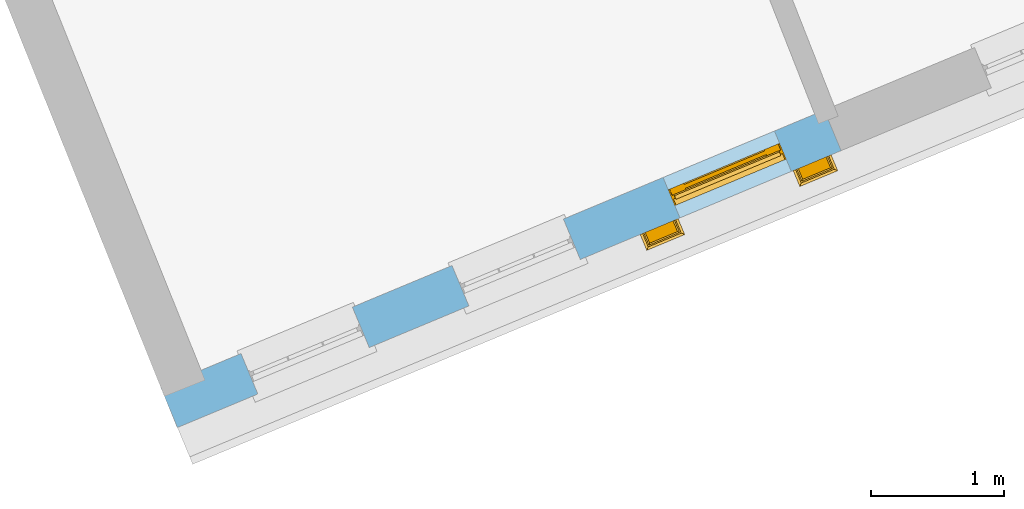
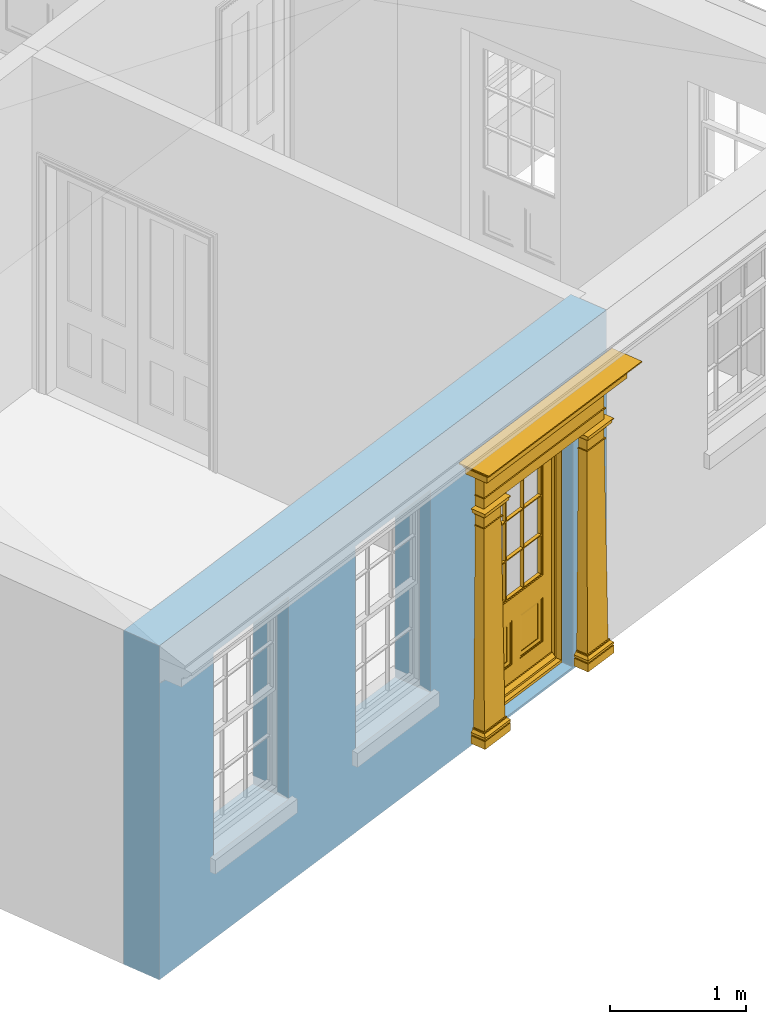
# One storey, part 4 of 19: 1 door, 3 openings, plus 1 element that does not belong to this part.
"""IFC2X3 building model written with IfcOpenShell, lengths in metres."""

import ifcopenshell
import ifcopenshell.guid

model = None  # the IFC model being written
_history = None  # IfcOwnerHistory: only IFC2X3 demands one
_inside = {}  # id of a spatial element -> (the spatial element, [elements in it])
_under = {}  # id of a project, library or spatial element -> (it, [spatial elements below it])
_declared = {}  # id of a project -> (the project, [libraries it declares])
_typed = {}  # id of a type object -> (the type object, [elements of that type])
_made_of = {}  # id of a material, layer set ... -> (it, [elements and type objects made of it])


def new_model(schema):
    """Start an empty IFC model of exactly this schema.

    Asked for "IFC4X3", IfcOpenShell would pick the latest addendum, in which some entities
    have other attributes; the version numbers below select the first issue.
    IFC2X3 requires an IfcOwnerHistory on every rooted entity: one is made here for all.
    """
    global model, _history
    if schema == "IFC4X3":
        model = ifcopenshell.file(schema_version=(4, 3, 0, 0))
    else:
        model = ifcopenshell.file(schema=schema)
    _inside.clear()
    _under.clear()
    _declared.clear()
    _typed.clear()
    _made_of.clear()
    _history = None
    if model.schema == "IFC2X3":
        org = make("IfcOrganization", Name="unknown")
        user = make(
            "IfcPersonAndOrganization",
            ThePerson=make("IfcPerson", FamilyName="unknown"),
            TheOrganization=org,
        )
        app = make(
            "IfcApplication",
            ApplicationDeveloper=org,
            Version="unknown",
            ApplicationFullName="unknown",
            ApplicationIdentifier="unknown",
        )
        _history = make(
            "IfcOwnerHistory",
            OwningUser=user,
            OwningApplication=app,
            ChangeAction="ADDED",
            CreationDate=0,
        )
    return model


def make(cls, **values):
    """One entity of the class cls with the attributes given. An attribute that is None is left unset."""
    return model.create_entity(
        cls, **{name: value for name, value in values.items() if value is not None}
    )


def rooted(cls, **values):
    """An entity with a GlobalId (a new one), such as an element, a storey or a relation."""
    return make(cls, GlobalId=ifcopenshell.guid.new(), OwnerHistory=_history, **values)


def si_unit(unit_type, name, prefix=None):
    """IfcSIUnit, for example si_unit("LENGTHUNIT", "METRE", prefix="MILLI")."""
    return make("IfcSIUnit", UnitType=unit_type, Prefix=prefix, Name=name)


def assignment(units):
    """IfcUnitAssignment: the units of a project."""
    return None if units is None else make("IfcUnitAssignment", Units=units)


def point(xyz):
    """IfcCartesianPoint."""
    return None if xyz is None else make("IfcCartesianPoint", Coordinates=xyz)


def direction(xyz):
    """IfcDirection."""
    return None if xyz is None else make("IfcDirection", DirectionRatios=xyz)


def frame(location, z_axis=None, x_axis=None):
    """IfcAxis2Placement3D, a coordinate frame: its origin and axes. An axis left out is left unset."""
    return make(
        "IfcAxis2Placement3D",
        Location=point(location),
        Axis=direction(z_axis),
        RefDirection=direction(x_axis),
    )


def origin():
    """The frame at (0, 0, 0) with its axes left unset."""
    return frame((0.0, 0.0, 0.0))


def place(relative_to, where):
    """IfcLocalPlacement: puts the frame where relative to a parent placement (None: the world)."""
    return make(
        "IfcLocalPlacement", PlacementRelTo=relative_to, RelativePlacement=where
    )


def context(
    kind, dimensions, precision=None, world=None, true_north=None, identifier=None
):
    """IfcGeometricRepresentationContext, for example the 3D "Model" context."""
    return make(
        "IfcGeometricRepresentationContext",
        ContextIdentifier=identifier,
        ContextType=kind,
        CoordinateSpaceDimension=dimensions,
        Precision=precision,
        WorldCoordinateSystem=world,
        TrueNorth=true_north,
    )


def subcontext(parent, identifier, kind, view, scale=None):
    """IfcGeometricRepresentationSubContext, for example "Body" below "Model"."""
    return make(
        "IfcGeometricRepresentationSubContext",
        ContextIdentifier=identifier,
        ContextType=kind,
        ParentContext=parent,
        TargetScale=scale,
        TargetView=view,
    )


def project(units=None, contexts=None):
    """IfcProject with its units and contexts."""
    return rooted(
        "IfcProject",
        Name="project",
        RepresentationContexts=contexts,
        UnitsInContext=assignment(units),
    )


def spatial(cls, under=None, at=None, **own):
    """A site, building, storey or space (cls), placed at a placement, below another one or the project."""
    s = rooted(cls, ObjectPlacement=at, **own)
    if under is not None:
        _under.setdefault(under.id(), (under, []))[1].append(s)
    return s


def polyline(points):
    """IfcPolyline through the points."""
    return make("IfcPolyline", Points=[point(p) for p in points])


def outline(outer, holes=None, kind="AREA"):
    """IfcArbitraryClosedProfileDef: a profile drawn as a closed curve; with holes, ...WithVoids."""
    if holes is None:
        return make("IfcArbitraryClosedProfileDef", ProfileType=kind, OuterCurve=outer)
    return make(
        "IfcArbitraryProfileDefWithVoids",
        ProfileType=kind,
        OuterCurve=outer,
        InnerCurves=holes,
    )


def extrude(swept, where, along, depth):
    """IfcExtrudedAreaSolid: the profile swept, set in the frame where, extruded along a direction by depth."""
    return make(
        "IfcExtrudedAreaSolid",
        SweptArea=swept,
        Position=where,
        ExtrudedDirection=direction(along),
        Depth=depth,
    )


def faces_of(points, faces, orient=None, outer=None):
    """IfcFace entities. A face is a list of loops; a loop is a list of indices into points, from 0.

    orient and outer hold one flag for each loop. By default every Orientation is true, the
    first loop of a face is its IfcFaceOuterBound and the others are IfcFaceBound.
    """
    made = []
    for i, loops in enumerate(faces):
        bounds = []
        for j, loop in enumerate(loops):
            is_outer = j == 0 if outer is None else outer[i][j]
            bounds.append(
                make(
                    "IfcFaceOuterBound" if is_outer else "IfcFaceBound",
                    Bound=make("IfcPolyLoop", Polygon=[points[k] for k in loop]),
                    Orientation=True if orient is None else orient[i][j],
                )
            )
        made.append(make("IfcFace", Bounds=bounds))
    return made


def faceted_brep(points, faces, orient=None, outer=None, voids=None):
    """IfcFacetedBrep: a solid bounded by flat faces; with voids (closed shells), ...WithVoids."""
    shared = [point(p) for p in points]
    hull = make("IfcClosedShell", CfsFaces=faces_of(shared, faces, orient, outer))
    if voids is None:
        return make("IfcFacetedBrep", Outer=hull)
    return make(
        "IfcFacetedBrepWithVoids",
        Outer=hull,
        Voids=[
            make(cls, CfsFaces=faces_of(shared, fs, o, b)) for cls, fs, o, b in voids
        ],
    )


def shape(context_of_items, identifier, shape_type, items):
    """IfcShapeRepresentation: the items that make up one representation, for example the "Body"."""
    return make(
        "IfcShapeRepresentation",
        ContextOfItems=context_of_items,
        RepresentationIdentifier=identifier,
        RepresentationType=shape_type,
        Items=items,
    )


def material(Name=None, Category=None):
    """IfcMaterial."""
    return make("IfcMaterial", Name=Name, Category=Category)


def layer(
    of_material, thickness, ventilated=None, Name=None, Category=None, Priority=None
):
    """IfcMaterialLayer: one layer of a wall or slab, of a material (None: an air gap)."""
    return make(
        "IfcMaterialLayer",
        Material=of_material,
        LayerThickness=thickness,
        IsVentilated=ventilated,
        Name=Name,
        Category=Category,
        Priority=Priority,
    )


def layer_set(layers, Name=None):
    """IfcMaterialLayerSet."""
    return make("IfcMaterialLayerSet", MaterialLayers=layers, LayerSetName=Name)


def layer_usage(for_layer_set, set_direction, sense, offset, extent=None):
    """IfcMaterialLayerSetUsage: how a layer set lies in its element."""
    return make(
        "IfcMaterialLayerSetUsage",
        ForLayerSet=for_layer_set,
        LayerSetDirection=set_direction,
        DirectionSense=sense,
        OffsetFromReferenceLine=offset,
        ReferenceExtent=extent,
    )


def made_of(thing, what):
    """Note that an element or type object is made of a material, layer set ...; save() writes the relation."""
    if what is not None:
        _made_of.setdefault(what.id(), (what, []))[1].append(thing)
    return thing


def element(
    cls,
    number,
    at=None,
    inside=None,
    cuts=None,
    type_object=None,
    material=None,
    context=None,
    identifier="Body",
    shape_type=None,
    held_by="IfcProductDefinitionShape",
    body=None,
    shapes=None,
    **own,
):
    """One element of the class cls, such as IfcWall. Its Tag is "e" and its number.

    at: its placement. inside: the storey or other place that contains it. cuts: it is an
    opening in that element (IfcRelVoidsElement). A single representation is given by context,
    identifier, shape_type and body (its items); several are given by shapes. held_by: the class
    of the entity that holds the representations. save() writes the other relations.
    """
    e = rooted(cls, Tag="e%d" % number, ObjectPlacement=at, **own)
    if body is not None:
        shapes = [shape(context, identifier, shape_type, body)]
    if shapes is not None:
        e.Representation = make(held_by, Representations=shapes)
    if inside is not None:
        _inside.setdefault(inside.id(), (inside, []))[1].append(e)
    if cuts is not None:
        rooted(
            "IfcRelVoidsElement", RelatingBuildingElement=cuts, RelatedOpeningElement=e
        )
    if type_object is not None:
        _typed.setdefault(type_object.id(), (type_object, []))[1].append(e)
    return made_of(e, material)


def fill(opening, filler):
    """IfcRelFillsElement: the door or window that sits in an opening."""
    return rooted(
        "IfcRelFillsElement",
        RelatingOpeningElement=opening,
        RelatedBuildingElement=filler,
    )


def aggregate(whole, parts):
    """IfcRelAggregates: a whole, such as a stair, and the parts it consists of."""
    return rooted("IfcRelAggregates", RelatingObject=whole, RelatedObjects=parts)


def save(model, path):
    """Write the relations noted so far, then the file.

    IfcRelAggregates (storeys below a building ...), IfcRelContainedInSpatialStructure (elements
    in a storey), IfcRelDefinesByType, IfcRelAssociatesMaterial and IfcRelDeclares: one each for
    every whole, place, type object, material and project.
    """
    for whole, parts in _under.values():
        aggregate(whole, parts)
    for where, things in _inside.values():
        rooted(
            "IfcRelContainedInSpatialStructure",
            RelatedElements=things,
            RelatingStructure=where,
        )
    for kind, things in _typed.values():
        rooted("IfcRelDefinesByType", RelatedObjects=things, RelatingType=kind)
    for what, things in _made_of.values():
        rooted("IfcRelAssociatesMaterial", RelatedObjects=things, RelatingMaterial=what)
    for by, libraries in _declared.values():
        rooted("IfcRelDeclares", RelatingContext=by, RelatedDefinitions=libraries)
    model.write(path)


model = new_model("IFC2X3")

# Units and contexts
model_context = context("Model", 3, world=origin())
body_context = subcontext(model_context, "Body", "Model", "MODEL_VIEW")
ifc_project = project(units=[si_unit("PLANEANGLEUNIT", "RADIAN"), si_unit("MASSUNIT", "GRAM", prefix="KILO"), si_unit("FORCEUNIT", "NEWTON", prefix="KILO"), si_unit("LENGTHUNIT", "METRE")], contexts=[model_context])

# Site, building, storey
site_placement = place(None, origin())
site = spatial("IfcSite", under=ifc_project, at=site_placement, CompositionType="ELEMENT")
building_placement = place(None, origin())
building = spatial("IfcBuilding", under=site, at=building_placement, Name="Building plot-0", CompositionType="ELEMENT")
storey_placement = place(None, origin())
storey = spatial("IfcBuildingStorey", under=building, at=storey_placement, Name="Floor 0", CompositionType="ELEMENT", Elevation=0.0)

# Wall, openings, door
ifc_material = material(Name="Masonry")
ifc_layer = layer(ifc_material, 0.33, ventilated=False)
ifc_layer_set = layer_set([ifc_layer], Name="My Wall")
ifc_layer_usage = layer_usage(ifc_layer_set, "AXIS2", "NEGATIVE", 0.08)
wall_placement = place(storey_placement, origin())
wall = element("IfcWallStandardCase", 1, at=wall_placement, inside=storey, material=ifc_layer_usage, Name="exterior", context=body_context, shape_type="SweptSolid", body=[
    extrude(outline(polyline([(16.1700267177394, 20.5032297368677), (16.2971036159413, 20.1986784900415), (21.3007494176732, 22.2864971898878), (21.1736725194713, 22.591048436714), (16.1700267177394, 20.5032297368677)])), origin(), (0.0, 0.0, 1.0), 3.0),
])
opening_1_placement = place(storey_placement, frame((0.0, 0.0, 0.75)))
element("IfcOpeningElement", 2, at=opening_1_placement, cuts=wall, Name="Opening", ObjectType="Opening", context=body_context, shape_type="SweptSolid", body=[
    extrude(outline(polyline([(16.9034002165821, 20.4516615009559), (17.7432233517695, 20.8020856747854), (17.6161464535675, 21.1066369216116), (16.7763233183802, 20.756212747782), (16.9034002165821, 20.4516615009559)])), origin(), (0.0, 0.0, 1.0), 1.82),
])
opening_2_placement = place(storey_placement, frame((0.0, 0.0, 0.75)))
element("IfcOpeningElement", 3, at=opening_2_placement, cuts=wall, Name="Opening", ObjectType="Opening", context=body_context, shape_type="SweptSolid", body=[
    extrude(outline(polyline([(18.4943752699811, 21.1155109417627), (19.3341984051684, 21.4659351155923), (19.2071215069665, 21.7704863624185), (18.3672983717792, 21.4200621885889), (18.4943752699811, 21.1155109417627)])), origin(), (0.0, 0.0, 1.0), 1.82),
])
opening_3_placement = place(storey_placement, frame((0.0, 0.0, 0.02)))
opening_3 = element("IfcOpeningElement", 4, at=opening_3_placement, cuts=wall, Name="Opening", ObjectType="Opening", context=body_context, shape_type="SweptSolid", body=[
    extrude(outline(polyline([(20.0853503233801, 21.7793603825696), (20.9251734585674, 22.1297845563992), (20.7980965603655, 22.4343358032253), (19.9582734251781, 22.0839116293958), (20.0853503233801, 21.7793603825696)])), origin(), (0.0, 0.0, 1.0), 2.08),
])
door_placement = place(storey_placement, frame((19.9890799459544, 22.0100810241046, 0.02), z_axis=(0.0, 0.0, 1.0), x_axis=(0.839823135187327, 0.350424173829563, 0.0)))
door = element("IfcDoor", 5, at=door_placement, inside=storey, Name="house entrance single storey", OverallHeight=2.08, OverallWidth=0.91, context=body_context, shape_type="Brep", held_by="IfcProductRepresentation", body=[
    faceted_brep([(-0.305, -0.25, 2.43), (-0.335, -0.25, 2.45), (1.245, -0.25, 2.45), (1.215, -0.25, 2.43), (-0.315, -0.25, 2.43), (-0.335, -0.25, 2.46), (1.245, -0.25, 2.46), (1.225, -0.25, 2.43), (-0.295, -0.25, 2.42), (1.205, -0.25, 2.42), (-0.315, -0.37, 2.43), (-0.305, -0.36, 2.43), (-0.335, -0.39, 2.45), (-0.335, -0.39, 2.46), (-0.395, -0.25, 2.52), (1.305, -0.25, 2.52), (1.245, -0.39, 2.46), (1.245, -0.39, 2.45), (1.225, -0.37, 2.43), (1.215, -0.36, 2.43), (-0.305, -0.25, 2.42), (1.215, -0.25, 2.42), (-0.285, -0.25, 2.41), (1.195, -0.25, 2.41), (-0.305, -0.36, 2.42), (-0.395, -0.45, 2.46), (-0.395, -0.25, 2.46), (-0.405, -0.25, 2.53), (1.315, -0.25, 2.53), (1.305, -0.25, 2.46), (1.305, -0.45, 2.46), (1.215, -0.36, 2.42), (-0.295, -0.35, 2.42), (1.205, -0.35, 2.42), (-0.285, -0.34, 2.41), (1.195, -0.34, 2.41), (-0.275, -0.25, 2.4), (1.185, -0.25, 2.4), (-0.395, -0.45, 2.52), (-0.405, -0.25, 2.52), (-0.415, -0.25, 2.54), (1.325, -0.25, 2.54), (1.315, -0.25, 2.52), (1.305, -0.45, 2.52), (-0.285, -0.25, 2.4), (-0.285, -0.34, 2.4), (1.195, -0.34, 2.4), (1.195, -0.25, 2.4), (-0.275, -0.25, 2.21), (1.185, -0.25, 2.21), (-0.405, -0.46, 2.52), (-0.405, -0.46, 2.53), (-0.415, -0.47, 2.54), (-0.425, -0.25, 2.55), (1.335, -0.25, 2.55), (1.325, -0.47, 2.54), (1.315, -0.46, 2.53), (1.315, -0.46, 2.52), (-0.275, -0.33, 2.4), (1.185, -0.33, 2.4), (-0.275, -0.33, 2.21), (1.185, -0.33, 2.21), (-0.275, -0.25, 2.2), (1.185, -0.25, 2.2), (-0.425, -0.48, 2.54), (-0.425, -0.25, 2.54), (-0.445, -0.25, 2.581), (1.355, -0.25, 2.581), (1.335, -0.25, 2.54), (1.335, -0.48, 2.54), (-0.285, -0.34, 2.21), (-0.285, -0.25, 2.21), (1.195, -0.34, 2.21), (1.195, -0.25, 2.21), (-0.285, -0.25, 2.2), (1.195, -0.25, 2.2), (-0.015, -0.25, 2.11), (0.925, -0.25, 2.11), (-0.425, -0.48, 2.55), (-0.435, -0.25, 2.556), (-0.473, -0.25, 2.591), (1.383, -0.25, 2.591), (1.345, -0.25, 2.556), (1.335, -0.48, 2.55), (-0.285, -0.34, 2.2), (1.195, -0.34, 2.2), (-0.275, -0.33, 2.2), (1.185, -0.33, 2.2), (-0.275, -0.25, 2.11), (1.185, -0.25, 2.11), (-0.015, -0.33, 2.11), (0.925, -0.33, 2.11), (-0.435, -0.49, 2.556), (-0.445, -0.5, 2.581), (-0.473, -0.528, 2.591), (-0.473, -0.25, 2.601), (1.383, -0.25, 2.601), (1.383, -0.528, 2.591), (1.355, -0.5, 2.581), (1.345, -0.49, 2.556), (-0.275, -0.33, 2.11), (1.185, -0.33, 2.11), (-0.025, -0.25, 2.1), (-0.315, -0.25, 2.1), (1.225, -0.25, 2.1), (0.935, -0.25, 2.1), (-0.015, -0.38, 2.1), (0.925, -0.25, 2.1), (-0.473, -0.528, 2.601), (1.383, -0.528, 2.601), (-0.325, -0.25, 2.11), (-0.325, -0.38, 2.11), (1.235, -0.38, 2.11), (1.235, -0.25, 2.11), (-0.015, -0.25, 2.1), (-0.035, -0.25, 2.07), (-0.305, -0.25, 2.07), (-0.325, -0.25, 2.1), (1.235, -0.25, 2.1), (0.945, -0.25, 2.07), (1.215, -0.25, 2.07), (-0.015, -0.38, 2.11), (0.925, -0.38, 2.11), (-0.325, -0.38, 2.1), (1.235, -0.38, 2.1), (-0.025, -0.37, 2.1), (-0.025, -0.25, 2.07), (-0.305, -0.25, 2.06), (-0.035, -0.25, 2.06), (-0.315, -0.25, 2.07), (-0.315, -0.37, 2.1), (1.225, -0.37, 2.1), (0.935, -0.25, 2.07), (1.225, -0.25, 2.07), (1.215, -0.25, 2.06), (0.945, -0.25, 2.06), (0.935, -0.37, 2.1), (0.925, -0.38, 2.1), (-0.025, -0.37, 2.07), (-0.035, -0.36, 2.07), (-0.305, -0.36, 2.06), (-0.305, -0.36, 2.07), (-0.035, -0.36, 2.06), (-0.285, -0.25, 2.04), (-0.055, -0.25, 2.04), (-0.315, -0.37, 2.07), (1.225, -0.37, 2.07), (0.945, -0.36, 2.07), (0.935, -0.37, 2.07), (1.215, -0.36, 2.07), (1.215, -0.36, 2.06), (1.195, -0.25, 2.04), (0.965, -0.25, 2.04), (0.945, -0.36, 2.06), (-0.285, -0.34, 2.04), (-0.055, -0.34, 2.04), (-0.065, -0.25, 2.03), (-0.275, -0.25, 2.03), (1.195, -0.34, 2.04), (1.185, -0.25, 2.03), (0.975, -0.25, 2.03), (0.965, -0.34, 2.04), (-0.285, -0.25, 2.03), (-0.285, -0.34, 2.03), (-0.055, -0.25, 2.03), (-0.055, -0.34, 2.03), (-0.275, -0.25, 1.94), (-0.065, -0.25, 1.94), (1.195, -0.25, 2.03), (1.195, -0.34, 2.03), (1.185, -0.25, 1.94), (0.975, -0.25, 1.94), (0.965, -0.25, 2.03), (0.965, -0.34, 2.03), (-0.275, -0.33, 2.03), (-0.065, -0.33, 2.03), (-0.275, -0.33, 1.94), (-0.065, -0.33, 1.94), (-0.275, -0.25, 1.93), (-0.065, -0.25, 1.93), (1.185, -0.33, 2.03), (1.185, -0.33, 1.94), (1.185, -0.25, 1.93), (0.975, -0.25, 1.93), (0.975, -0.33, 1.94), (0.975, -0.33, 2.03), (-0.285, -0.25, 1.94), (-0.285, -0.34, 1.94), (-0.055, -0.34, 1.94), (-0.055, -0.25, 1.94), (-0.285, -0.25, 1.93), (-0.055, -0.25, 1.93), (-0.295, -0.25, 0.13), (-0.045, -0.25, 0.13), (1.195, -0.34, 1.94), (1.195, -0.25, 1.94), (1.195, -0.25, 1.93), (1.205, -0.25, 0.13), (0.955, -0.25, 0.13), (0.965, -0.25, 1.94), (0.965, -0.25, 1.93), (0.965, -0.34, 1.94), (-0.285, -0.34, 1.93), (-0.055, -0.34, 1.93), (-0.275, -0.33, 1.93), (-0.065, -0.33, 1.93), (-0.295, -0.35, 0.13), (-0.045, -0.35, 0.13), (-0.305, -0.25, 0.12), (-0.035, -0.25, 0.12), (1.195, -0.34, 1.93), (1.185, -0.33, 1.93), (1.205, -0.35, 0.13), (1.215, -0.25, 0.12), (0.945, -0.25, 0.12), (0.955, -0.35, 0.13), (0.975, -0.33, 1.93), (0.965, -0.34, 1.93), (-0.305, -0.25, 0.13), (-0.305, -0.36, 0.13), (-0.035, -0.25, 0.13), (-0.035, -0.36, 0.13), (-0.325, -0.25, 0.1), (-0.015, -0.25, 0.1), (1.215, -0.36, 0.13), (1.215, -0.25, 0.13), (1.235, -0.25, 0.1), (0.925, -0.25, 0.1), (0.945, -0.25, 0.13), (0.945, -0.36, 0.13), (-0.305, -0.36, 0.12), (-0.035, -0.36, 0.12), (-0.325, -0.38, 0.1), (-0.015, -0.38, 0.1), (-0.325, -0.25, 0.08), (-0.015, -0.25, 0.08), (1.215, -0.36, 0.12), (1.235, -0.38, 0.1), (1.235, -0.25, 0.08), (0.925, -0.25, 0.08), (0.925, -0.38, 0.1), (0.945, -0.36, 0.12), (-0.325, -0.38, 0.08), (-0.015, -0.38, 0.08), (-0.315, -0.25, 0.07), (-0.025, -0.25, 0.07), (1.235, -0.38, 0.08), (1.225, -0.25, 0.07), (0.935, -0.25, 0.07), (0.925, -0.38, 0.08), (-0.315, -0.37, 0.07), (-0.025, -0.37, 0.07), (-0.015, -0.25, 0.0), (-0.325, -0.25, 0.0), (1.225, -0.37, 0.07), (1.235, -0.25, 0.0), (0.925, -0.25, 0.0), (0.935, -0.37, 0.07), (-0.325, -0.25, 0.07), (-0.325, -0.38, 0.07), (-0.015, -0.38, 0.07), (-0.015, -0.25, 0.07), (-0.015, -0.38, 0.0), (-0.325, -0.38, 0.0), (1.235, -0.38, 0.07), (1.235, -0.25, 0.07), (1.235, -0.38, 0.0), (0.925, -0.38, 0.0), (0.925, -0.25, 0.07), (0.925, -0.38, 0.07), (0.885, -0.072, 0.025), (0.025, -0.072, 0.025), (0.025, -0.1, 0.025), (0.885, -0.1, 0.025), (0.9, -0.02, 0.025), (0.01, -0.02, 0.025), (0.9, -0.072, 0.025), (0.91, -0.02, 0.0), (0.0, -0.02, 0.0), (0.01, -0.072, 0.025), (0.9, -0.072, 2.07), (0.9, -0.02, 2.07), (0.885, -0.072, 2.055), (0.91, -0.02, 2.08), (0.01, -0.02, 2.07), (0.0, -0.02, 2.08), (0.01, -0.072, 2.07), (0.025, -0.072, 2.055), (0.0, -0.15, 0.0), (0.0, -0.15, 2.08), (0.91, -0.15, 0.0), (0.01, -0.15, 0.025), (0.01, -0.15, 2.07), (0.9, -0.15, 0.025), (0.91, -0.15, 2.08), (0.01, -0.1, 0.025), (0.01, -0.1, 2.065), (0.9, -0.15, 2.07), (0.025, -0.1, 2.055), (0.9, -0.1, 2.065), (0.9, -0.1, 0.025), (0.885, -0.1, 2.055), (0.898, -0.07, 2.068), (0.898, -0.02, 2.068), (0.012, -0.02, 2.068), (0.012, -0.07, 2.068), (0.898, -0.07, 0.075), (0.898, -0.02, 0.027), (0.012, -0.02, 0.027), (0.012, -0.07, 0.075), (0.898, -0.07, 0.027), (0.012, -0.07, 0.027), (0.883, -0.07, 0.027), (0.883, -0.07, 0.075), (0.027, -0.07, 0.027), (0.027, -0.07, 0.075), (0.883, -0.08, 0.075), (0.883, -0.11, 0.045), (0.027, -0.11, 0.045), (0.027, -0.08, 0.075), (0.027, -0.11, 0.027), (0.883, -0.11, 0.027), (0.745, -0.05, 0.265), (0.545, -0.05, 0.265), (0.545, -0.055, 0.265), (0.745, -0.055, 0.265), (0.745, -0.05, 0.58), (0.545, -0.05, 0.58), (0.545, -0.055, 0.58), (0.515, -0.06, 0.235), (0.775, -0.06, 0.235), (0.745, -0.055, 0.58), (0.515, -0.06, 0.61), (0.515, -0.065, 0.235), (0.775, -0.065, 0.235), (0.775, -0.06, 0.61), (0.515, -0.065, 0.61), (0.785, -0.065, 0.225), (0.505, -0.065, 0.225), (0.775, -0.065, 0.61), (0.505, -0.065, 0.62), (0.785, -0.065, 0.62), (0.505, -0.07, 0.225), (0.785, -0.07, 0.225), (0.505, -0.07, 0.62), (0.785, -0.07, 0.62), (0.405, -0.07, 0.62), (0.405, -0.07, 0.225), (0.785, -0.07, 0.82), (0.125, -0.07, 0.82), (0.405, -0.065, 0.62), (0.405, -0.065, 0.225), (0.125, -0.07, 0.225), (0.785, -0.06, 0.82), (0.125, -0.06, 0.82), (0.125, -0.07, 0.62), (0.125, -0.065, 0.62), (0.395, -0.065, 0.61), (0.395, -0.065, 0.235), (0.125, -0.065, 0.225), (0.785, -0.07, 1.895), (0.558333, -0.06, 0.83), (0.351667, -0.06, 0.83), (0.125, -0.07, 1.895), (0.125, -0.06, 1.895), (0.785, -0.06, 1.895), (0.135, -0.065, 0.61), (0.395, -0.06, 0.61), (0.395, -0.06, 0.235), (0.135, -0.065, 0.235), (0.568333, -0.06, 0.83), (0.558333, -0.03, 0.83), (0.351667, -0.03, 0.83), (0.341667, -0.06, 0.83), (0.135, -0.06, 1.185), (0.135, -0.06, 1.53), (0.775, -0.06, 1.53), (0.775, -0.06, 1.185), (0.135, -0.06, 0.61), (0.365, -0.055, 0.58), (0.365, -0.055, 0.265), (0.135, -0.06, 0.235), (0.568333, -0.06, 1.175), (0.558333, -0.06, 1.175), (0.775, -0.06, 0.83), (0.558333, -0.03, 1.175), (0.785, -0.03, 0.82), (0.125, -0.03, 0.82), (0.351667, -0.03, 1.175), (0.351667, -0.06, 1.175), (0.341667, -0.06, 1.175), (0.135, -0.06, 0.83), (0.135, -0.06, 1.175), (0.135, -0.03, 1.185), (0.135, -0.03, 1.53), (0.135, -0.06, 1.54), (0.351667, -0.06, 1.885), (0.558333, -0.06, 1.885), (0.775, -0.03, 1.53), (0.775, -0.03, 1.185), (0.775, -0.06, 1.175), (0.775, -0.06, 1.54), (0.165, -0.055, 0.58), (0.365, -0.05, 0.58), (0.365, -0.05, 0.265), (0.165, -0.055, 0.265), (0.568333, -0.03, 0.83), (0.568333, -0.03, 1.175), (0.568333, -0.06, 1.185), (0.558333, -0.06, 1.185), (0.775, -0.03, 0.83), (0.785, -0.02, 0.82), (0.125, -0.02, 0.82), (0.341667, -0.03, 0.83), (0.341667, -0.03, 1.175), (0.351667, -0.06, 1.185), (0.341667, -0.06, 1.185), (0.135, -0.03, 0.83), (0.341667, -0.03, 1.185), (0.125, -0.03, 1.895), (0.341667, -0.03, 1.53), (0.341667, -0.06, 1.53), (0.135, -0.06, 1.885), (0.341667, -0.06, 1.54), (0.341667, -0.06, 1.885), (0.558333, -0.03, 1.885), (0.351667, -0.03, 1.885), (0.568333, -0.06, 1.885), (0.785, -0.03, 1.895), (0.568333, -0.03, 1.185), (0.568333, -0.06, 1.53), (0.568333, -0.03, 1.53), (0.568333, -0.06, 1.54), (0.775, -0.06, 1.885), (0.165, -0.05, 0.58), (0.165, -0.05, 0.265), (0.775, -0.03, 1.175), (0.558333, -0.06, 1.53), (0.351667, -0.03, 1.185), (0.558333, -0.03, 1.185), (0.505, -0.02, 0.62), (0.405, -0.02, 0.62), (0.125, -0.02, 1.895), (0.785, -0.02, 1.895), (0.351667, -0.06, 1.53), (0.135, -0.03, 1.175), (0.135, -0.03, 1.54), (0.341667, -0.03, 1.54), (0.135, -0.03, 1.885), (0.351667, -0.06, 1.54), (0.558333, -0.03, 1.54), (0.558333, -0.06, 1.54), (0.351667, -0.03, 1.54), (0.775, -0.03, 1.54), (0.568333, -0.03, 1.54), (0.775, -0.03, 1.885), (0.558333, -0.03, 1.53), (0.405, -0.02, 0.225), (0.505, -0.02, 0.225), (0.125, -0.02, 0.62), (0.785, -0.02, 0.62), (0.351667, -0.03, 1.53), (0.341667, -0.03, 1.885), (0.568333, -0.03, 1.885), (0.405, -0.025, 0.225), (0.405, -0.025, 0.62), (0.505, -0.025, 0.62), (0.505, -0.025, 0.225), (0.125, -0.025, 0.62), (0.785, -0.025, 0.62), (0.395, -0.025, 0.235), (0.395, -0.025, 0.61), (0.125, -0.02, 0.225), (0.125, -0.025, 0.225), (0.515, -0.025, 0.61), (0.515, -0.025, 0.235), (0.785, -0.02, 0.225), (0.785, -0.025, 0.225), (0.135, -0.025, 0.61), (0.775, -0.025, 0.61), (0.135, -0.025, 0.235), (0.395, -0.03, 0.235), (0.395, -0.03, 0.61), (0.515, -0.03, 0.61), (0.515, -0.03, 0.235), (0.775, -0.025, 0.235), (0.135, -0.03, 0.61), (0.775, -0.03, 0.61), (0.135, -0.03, 0.235), (0.365, -0.035, 0.265), (0.365, -0.035, 0.58), (0.545, -0.035, 0.58), (0.545, -0.035, 0.265), (0.775, -0.03, 0.235), (0.165, -0.035, 0.58), (0.745, -0.035, 0.58), (0.165, -0.035, 0.265), (0.365, -0.04, 0.58), (0.365, -0.04, 0.265), (0.545, -0.04, 0.58), (0.545, -0.04, 0.265), (0.745, -0.035, 0.265), (0.165, -0.04, 0.58), (0.745, -0.04, 0.58), (0.165, -0.04, 0.265), (0.745, -0.04, 0.265)], [[[0, 1, 2, 3]], [[0, 4, 1]], [[1, 5, 6, 2]], [[7, 3, 2]], [[8, 0, 3, 9]], [[10, 4, 0, 11]], [[12, 1, 4, 10]], [[1, 12, 13, 5]], [[5, 14, 15, 6]], [[6, 16, 17, 2]], [[7, 18, 19, 3]], [[2, 17, 18, 7]], [[8, 20, 0]], [[21, 9, 3]], [[22, 8, 9, 23]], [[11, 0, 20, 24]], [[10, 11, 19, 18]], [[12, 10, 18, 17]], [[25, 26, 5, 13]], [[13, 12, 17, 16]], [[5, 26, 14]], [[14, 27, 28, 15]], [[29, 6, 15]], [[29, 30, 16, 6]], [[3, 19, 31, 21]], [[24, 20, 8, 32]], [[21, 31, 33, 9]], [[32, 8, 22, 34]], [[9, 33, 35, 23]], [[36, 22, 23, 37]], [[11, 24, 31, 19]], [[38, 14, 26, 25]], [[25, 13, 16, 30]], [[14, 39, 27]], [[27, 40, 41, 28]], [[42, 15, 28]], [[15, 43, 30, 29]], [[24, 32, 33, 31]], [[34, 22, 44, 45]], [[32, 34, 35, 33]], [[23, 35, 46, 47]], [[36, 44, 22]], [[47, 37, 23]], [[48, 36, 37, 49]], [[50, 39, 14, 38]], [[38, 25, 30, 43]], [[51, 27, 39, 50]], [[52, 40, 27, 51]], [[40, 53, 54, 41]], [[41, 55, 56, 28]], [[42, 57, 43, 15]], [[28, 56, 57, 42]], [[45, 44, 36, 58]], [[34, 45, 46, 35]], [[47, 46, 59, 37]], [[60, 58, 36, 48]], [[59, 61, 49, 37]], [[62, 48, 49, 63]], [[50, 38, 43, 57]], [[51, 50, 57, 56]], [[64, 65, 40, 52]], [[52, 51, 56, 55]], [[40, 65, 53]], [[53, 66, 67, 54]], [[68, 41, 54]], [[68, 69, 55, 41]], [[45, 58, 59, 46]], [[58, 60, 61, 59]], [[70, 60, 48, 71]], [[61, 72, 73, 49]], [[71, 48, 62, 74]], [[49, 73, 75, 63]], [[76, 62, 63, 77]], [[78, 53, 65, 64]], [[64, 52, 55, 69]], [[53, 79, 66]], [[66, 80, 81, 67]], [[82, 54, 67]], [[54, 83, 69, 68]], [[60, 70, 72, 61]], [[84, 70, 71, 74]], [[72, 85, 75, 73]], [[86, 84, 74, 62]], [[85, 87, 63, 75]], [[76, 88, 62]], [[89, 77, 63]], [[90, 76, 77, 91]], [[92, 79, 53, 78]], [[93, 66, 79, 92]], [[80, 66, 93, 94]], [[80, 95, 96, 81]], [[97, 98, 67, 81]], [[82, 99, 83, 54]], [[67, 98, 99, 82]], [[70, 84, 85, 72]], [[84, 86, 87, 85]], [[100, 86, 62, 88]], [[87, 101, 89, 63]], [[88, 76, 102, 103]], [[77, 89, 104, 105]], [[76, 90, 106]], [[91, 77, 107]], [[86, 90, 91, 87]], [[108, 95, 80, 94]], [[96, 109, 97, 81]], [[86, 100, 90]], [[100, 88, 110, 111]], [[101, 87, 91]], [[89, 101, 112, 113]], [[76, 114, 102]], [[102, 115, 116, 103]], [[110, 88, 103, 117]], [[89, 113, 118, 104]], [[119, 105, 104, 120]], [[107, 77, 105]], [[90, 121, 106]], [[106, 114, 76]], [[107, 122, 91]], [[111, 121, 90, 100]], [[110, 117, 123, 111]], [[122, 112, 101, 91]], [[118, 113, 112, 124]], [[102, 114, 106, 125]], [[102, 126, 115]], [[127, 116, 115, 128]], [[103, 116, 129]], [[117, 103, 130, 123]], [[104, 118, 124, 131]], [[119, 132, 105]], [[104, 133, 120]], [[120, 134, 135, 119]], [[107, 105, 136, 137]], [[106, 121, 111, 123]], [[107, 137, 122]], [[122, 137, 124, 112]], [[130, 125, 106, 123]], [[126, 102, 125, 138]], [[115, 126, 138, 139]], [[116, 127, 140, 141]], [[128, 115, 139, 142]], [[143, 127, 128, 144]], [[129, 116, 141, 145]], [[103, 129, 145, 130]], [[136, 131, 124, 137]], [[133, 104, 131, 146]], [[132, 119, 147, 148]], [[105, 132, 148, 136]], [[120, 133, 146, 149]], [[134, 120, 149, 150]], [[134, 151, 152, 135]], [[119, 135, 153, 147]], [[138, 125, 130, 145]], [[141, 139, 138, 145]], [[127, 143, 154, 140]], [[142, 139, 141, 140]], [[144, 128, 142, 155]], [[156, 157, 143, 144]], [[136, 148, 146, 131]], [[147, 149, 146, 148]], [[147, 153, 150, 149]], [[151, 134, 150, 158]], [[159, 160, 152, 151]], [[135, 152, 161, 153]], [[143, 162, 163, 154]], [[140, 154, 155, 142]], [[164, 144, 155, 165]], [[166, 157, 156, 167]], [[157, 162, 143]], [[144, 164, 156]], [[158, 150, 153, 161]], [[168, 151, 158, 169]], [[159, 170, 171, 160]], [[172, 152, 160]], [[168, 159, 151]], [[152, 172, 173, 161]], [[96, 95, 108, 109]], [[108, 94, 97, 109]], [[97, 94, 93, 98]], [[174, 163, 162, 157]], [[155, 154, 163, 165]], [[164, 165, 175, 156]], [[157, 166, 176, 174]], [[167, 156, 175, 177]], [[178, 166, 167, 179]], [[158, 161, 173, 169]], [[169, 180, 159, 168]], [[170, 159, 180, 181]], [[170, 182, 183, 171]], [[160, 171, 184, 185]], [[173, 172, 160, 185]], [[98, 93, 92, 99]], [[99, 92, 78, 83]], [[69, 83, 78, 64]], [[174, 175, 165, 163]], [[186, 187, 176, 166]], [[174, 176, 177, 175]], [[177, 188, 189, 167]], [[178, 190, 186, 166]], [[167, 189, 191, 179]], [[192, 178, 179, 193]], [[185, 180, 169, 173]], [[181, 180, 185, 184]], [[194, 195, 170, 181]], [[196, 182, 170, 195]], [[182, 197, 198, 183]], [[199, 171, 183, 200]], [[201, 184, 171, 199]], [[190, 202, 187, 186]], [[177, 176, 187, 188]], [[191, 189, 188, 203]], [[204, 202, 190, 178]], [[191, 203, 205, 179]], [[178, 192, 206, 204]], [[193, 179, 205, 207]], [[208, 192, 193, 209]], [[181, 184, 201, 194]], [[210, 196, 195, 194]], [[210, 211, 182, 196]], [[211, 212, 197, 182]], [[197, 213, 214, 198]], [[183, 198, 215, 216]], [[217, 200, 183, 216]], [[199, 200, 217, 201]], [[202, 203, 188, 187]], [[204, 205, 203, 202]], [[192, 218, 219, 206]], [[204, 206, 207, 205]], [[220, 193, 207, 221]], [[208, 218, 192]], [[193, 220, 209]], [[222, 208, 209, 223]], [[217, 210, 194, 201]], [[216, 211, 210, 217]], [[212, 211, 216, 215]], [[212, 224, 225, 197]], [[225, 213, 197]], [[213, 226, 227, 214]], [[228, 198, 214]], [[198, 228, 229, 215]], [[218, 208, 230, 219]], [[221, 207, 206, 219]], [[209, 220, 221, 231]], [[208, 222, 232, 230]], [[223, 209, 231, 233]], [[234, 222, 223, 235]], [[224, 212, 215, 229]], [[213, 225, 224, 236]], [[226, 213, 236, 237]], [[226, 238, 239, 227]], [[214, 227, 240, 241]], [[228, 214, 241, 229]], [[231, 221, 219, 230]], [[234, 242, 232, 222]], [[233, 231, 230, 232]], [[235, 223, 233, 243]], [[244, 234, 235, 245]], [[229, 241, 236, 224]], [[241, 240, 237, 236]], [[246, 238, 226, 237]], [[238, 247, 248, 239]], [[227, 239, 249, 240]], [[234, 244, 250, 242]], [[243, 233, 232, 242]], [[245, 235, 243, 251]], [[252, 253, 244, 245]], [[240, 249, 246, 237]], [[247, 238, 246, 254]], [[255, 256, 248, 247]], [[239, 248, 257, 249]], [[258, 259, 250, 244]], [[242, 250, 251, 243]], [[251, 260, 261, 245]], [[262, 263, 253, 252]], [[253, 258, 244]], [[245, 261, 252]], [[254, 246, 249, 257]], [[264, 265, 247, 254]], [[266, 267, 256, 255]], [[268, 248, 256]], [[265, 255, 247]], [[269, 257, 248, 268]], [[258, 253, 263, 259]], [[251, 250, 259, 260]], [[252, 261, 260, 262]], [[259, 263, 262, 260]], [[254, 257, 269, 264]], [[255, 265, 264, 266]], [[266, 264, 269, 267]], [[268, 256, 267, 269]], [[270, 271, 272, 273]], [[271, 270, 274, 275]], [[276, 274, 270]], [[274, 277, 278, 275]], [[279, 271, 275]], [[280, 281, 274, 276]], [[276, 270, 282, 280]], [[281, 283, 277, 274]], [[284, 275, 278, 285]], [[286, 287, 271, 279]], [[275, 284, 286, 279]], [[281, 284, 285, 283]], [[280, 286, 284, 281]], [[285, 278, 288, 289]], [[290, 288, 278, 277]], [[288, 291, 292, 289]], [[288, 290, 293, 291]], [[294, 290, 277, 283]], [[295, 296, 292, 291]], [[297, 293, 290, 294]], [[291, 293, 273, 272]], [[272, 298, 296, 295]], [[295, 291, 272]], [[293, 297, 299, 300]], [[300, 273, 293]], [[287, 298, 272, 271]], [[300, 299, 301, 273]], [[282, 287, 286, 280]], [[282, 270, 273, 301]], [[289, 294, 283, 285]], [[287, 282, 301, 298]], [[302, 303, 304, 305]], [[306, 307, 303, 302]], [[308, 309, 305, 304]], [[310, 307, 306]], [[308, 311, 309]], [[307, 310, 312]], [[313, 312, 310, 306]], [[311, 308, 314]], [[309, 311, 314, 315]], [[308, 307, 312, 314]], [[316, 317, 312, 313]], [[315, 314, 318, 319]], [[320, 314, 312, 321]], [[321, 312, 317]], [[320, 318, 314]], [[322, 323, 324, 325]], [[322, 326, 327, 323]], [[327, 328, 324, 323]], [[325, 324, 329, 330]], [[331, 326, 322, 325]], [[331, 328, 327, 326]], [[324, 328, 332, 329]], [[330, 329, 333, 334]], [[330, 335, 331, 325]], [[335, 332, 328, 331]], [[329, 332, 336, 333]], [[337, 334, 333, 338]], [[334, 339, 335, 330]], [[339, 336, 332, 335]], [[340, 338, 333, 336]], [[337, 341, 339, 334]], [[337, 338, 342, 343]], [[336, 339, 341, 340]], [[338, 340, 344, 342]], [[343, 345, 341, 337]], [[313, 306, 343, 342]], [[345, 344, 340, 341]], [[342, 344, 346, 347]], [[345, 343, 306]], [[315, 313, 342, 347]], [[344, 345, 348]], [[348, 349, 346, 344]], [[347, 346, 350, 351]], [[345, 306, 302, 348]], [[319, 316, 313, 315]], [[315, 347, 352, 309]], [[353, 354, 349, 348]], [[346, 349, 355]], [[346, 355, 356, 350]], [[357, 358, 351, 350]], [[351, 359, 352, 347]], [[302, 360, 348]], [[318, 317, 316, 319]], [[352, 355, 309]], [[354, 353, 361, 362]], [[363, 349, 354, 364]], [[348, 360, 365, 353]], [[305, 309, 355, 349]], [[359, 356, 355, 352]], [[350, 356, 366, 357]], [[358, 357, 367, 368]], [[369, 359, 351, 358]], [[363, 360, 302, 305]], [[317, 318, 320, 321]], [[370, 361, 353]], [[362, 361, 371, 372]], [[362, 373, 354]], [[363, 305, 349]], [[364, 354, 374, 375]], [[360, 363, 364, 365]], [[376, 377, 353, 365]], [[369, 366, 356, 359]], [[357, 366, 378, 367]], [[368, 367, 379, 380]], [[368, 381, 369, 358]], [[370, 382, 383, 361]], [[370, 353, 384]], [[361, 383, 385, 371]], [[386, 387, 372, 371]], [[372, 388, 389, 362]], [[362, 389, 390, 373]], [[373, 391, 354]], [[392, 374, 354]], [[375, 374, 393, 394]], [[395, 364, 375]], [[365, 364, 396, 397]], [[398, 399, 377, 376]], [[400, 353, 377]], [[401, 376, 365]], [[381, 378, 366, 369]], [[367, 378, 402, 379]], [[379, 403, 404, 380]], [[380, 405, 381, 368]], [[406, 407, 382, 370]], [[383, 382, 408, 409]], [[384, 353, 400]], [[410, 406, 370, 384]], [[385, 383, 389, 388]], [[371, 385, 407, 406]], [[411, 412, 387, 386]], [[387, 413, 372]], [[406, 386, 371]], [[413, 414, 388, 372]], [[390, 389, 415, 416]], [[373, 390, 414, 413]], [[391, 373, 413, 417]], [[391, 392, 354]], [[416, 374, 392, 390]], [[416, 418, 393, 374]], [[394, 393, 387, 419]], [[420, 421, 375, 394]], [[422, 364, 395]], [[423, 395, 375, 421]], [[424, 396, 364]], [[425, 397, 396, 426]], [[427, 365, 397]], [[428, 386, 399, 398]], [[429, 408, 377, 399]], [[430, 431, 398, 376]], [[377, 408, 382, 400]], [[401, 432, 430, 376]], [[401, 365, 433]], [[405, 402, 378, 381]], [[379, 402, 434, 403]], [[404, 403, 434, 435]], [[404, 435, 405, 380]], [[382, 407, 436, 400]], [[437, 409, 408, 430]], [[409, 415, 389, 383]], [[384, 400, 436, 410]], [[406, 410, 386]], [[438, 439, 385, 388]], [[407, 385, 439, 429]], [[440, 441, 412, 411]], [[419, 387, 412, 442]], [[443, 411, 386, 428]], [[387, 417, 413]], [[388, 414, 418, 438]], [[421, 416, 415, 444]], [[414, 390, 392, 445]], [[417, 445, 392, 391]], [[420, 418, 416, 421]], [[414, 445, 393, 418]], [[393, 445, 387]], [[446, 394, 419]], [[420, 394, 446, 447]], [[424, 364, 422]], [[395, 446, 448, 422]], [[423, 447, 446, 395]], [[421, 444, 449, 423]], [[396, 424, 423, 449]], [[450, 451, 397, 425]], [[449, 452, 426, 396]], [[419, 428, 425, 426]], [[427, 433, 365]], [[427, 397, 451, 432]], [[436, 399, 386]], [[453, 428, 398]], [[430, 408, 429, 431]], [[429, 399, 436, 407]], [[454, 453, 398, 431]], [[454, 432, 401, 453]], [[437, 430, 432, 451]], [[453, 401, 433, 455]], [[434, 402, 405, 435]], [[456, 439, 409, 437]], [[409, 439, 438, 415]], [[410, 436, 386]], [[431, 429, 439, 456]], [[457, 441, 440, 458]], [[441, 459, 412]], [[440, 411, 460]], [[412, 304, 442]], [[428, 419, 442, 443]], [[411, 443, 303]], [[417, 387, 445]], [[461, 438, 418, 420]], [[444, 415, 438, 461]], [[419, 448, 446]], [[461, 420, 447, 452]], [[462, 424, 422, 448]], [[447, 423, 424, 462]], [[451, 449, 444, 437]], [[451, 450, 452, 449]], [[454, 450, 425, 463]], [[452, 447, 462, 426]], [[463, 425, 428]], [[426, 462, 419]], [[427, 463, 455, 433]], [[432, 454, 463, 427]], [[453, 455, 428]], [[431, 456, 450, 454]], [[456, 437, 444, 461]], [[464, 465, 441, 457]], [[458, 440, 466, 467]], [[458, 307, 308, 457]], [[465, 468, 459, 441]], [[308, 304, 412, 459]], [[411, 303, 307, 460]], [[469, 466, 440, 460]], [[304, 303, 443, 442]], [[462, 448, 419]], [[452, 450, 456, 461]], [[455, 463, 428]], [[465, 464, 470, 471]], [[457, 472, 473, 464]], [[474, 475, 467, 466]], [[476, 458, 467, 477]], [[458, 476, 307]], [[472, 457, 308]], [[478, 468, 465, 471]], [[472, 459, 468, 473]], [[472, 308, 459]], [[460, 307, 476]], [[469, 479, 474, 466]], [[477, 469, 460, 476]], [[480, 470, 464, 473]], [[481, 482, 471, 470]], [[475, 474, 483, 484]], [[477, 467, 475, 485]], [[473, 468, 478, 480]], [[482, 486, 478, 471]], [[485, 479, 469, 477]], [[487, 483, 474, 479]], [[470, 480, 488, 481]], [[489, 490, 482, 481]], [[484, 483, 491, 492]], [[485, 475, 484, 493]], [[480, 478, 486, 488]], [[490, 494, 486, 482]], [[493, 487, 479, 485]], [[495, 491, 483, 487]], [[481, 488, 496, 489]], [[497, 490, 489, 498]], [[491, 499, 500, 492]], [[493, 484, 492, 501]], [[488, 486, 494, 496]], [[497, 502, 494, 490]], [[501, 495, 487, 493]], [[503, 499, 491, 495]], [[489, 496, 504, 498]], [[504, 502, 497, 498]], [[500, 499, 503, 505]], [[501, 492, 500, 505]], [[494, 502, 504, 496]], [[503, 495, 501, 505]], [[289, 292, 297, 294]], [[292, 296, 299, 297]], [[298, 301, 299, 296]]]),
])
fill(opening_3, door)

save(model, "model.ifc")
